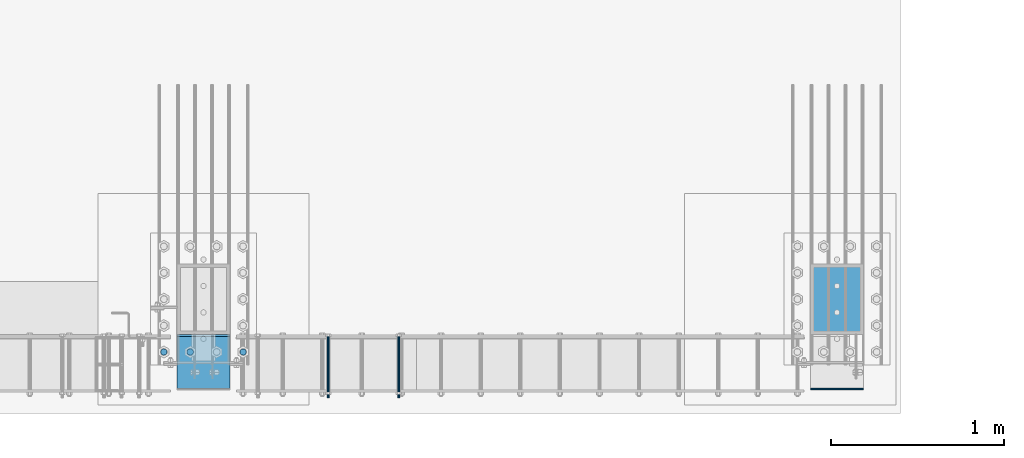
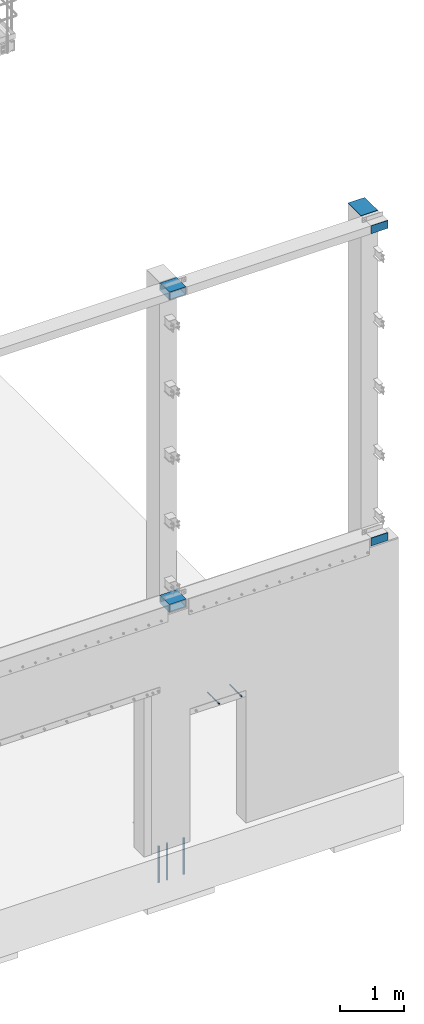
# One storey, part 1087 of 1876: 10 beams, 5 elements without a shape of their own.
"""IFC2X3 building model written with IfcOpenShell, lengths in millimetres."""

from ifc_helpers import new_model, si_unit, frame, origin_with_axes, place, context, subcontext, project, spatial, faceted_brep, material, type_object, element, aggregate, save


model = new_model("IFC2X3")

# Units and contexts
model_context = context("Model", 3, precision=1e-05, world=origin_with_axes())
body_context = subcontext(model_context, "Body", "Model", "MODEL_VIEW")
ifc_project = project(units=[si_unit("LENGTHUNIT", "METRE", prefix="MILLI"), si_unit("AREAUNIT", "SQUARE_METRE"), si_unit("VOLUMEUNIT", "CUBIC_METRE"), si_unit("MASSUNIT", "GRAM", prefix="KILO"), si_unit("TIMEUNIT", "SECOND"), si_unit("PLANEANGLEUNIT", "RADIAN"), si_unit("SOLIDANGLEUNIT", "STERADIAN"), si_unit("THERMODYNAMICTEMPERATUREUNIT", "DEGREE_CELSIUS"), si_unit("LUMINOUSINTENSITYUNIT", "LUMEN")], contexts=[model_context])

# Site, building, storey
site_placement = place(None, origin_with_axes())
site = spatial("IfcSite", under=ifc_project, at=site_placement, CompositionType="ELEMENT")
building_placement = place(site_placement, origin_with_axes())
building = spatial("IfcBuilding", under=site, at=building_placement, Name="Undefined", CompositionType="ELEMENT")
storey_placement = place(building_placement, origin_with_axes())
storey = spatial("IfcBuildingStorey", under=building, at=storey_placement, Name="Undefined", CompositionType="ELEMENT", Elevation=0.0)

# Assembly, beams
assembly_1_placement = place(storey_placement, origin_with_axes())
assembly_1 = element("IfcElementAssembly", 1, at=assembly_1_placement, inside=storey, Name="COLUMN", AssemblyPlace="NOTDEFINED", PredefinedType="RIGID_FRAME")
ifc_material_1 = material()
beam_type_1 = type_object("IfcBeamType", Name="HSS12X6X1/2", PredefinedType="NOTDEFINED")
beam_1_placement = place(assembly_1_placement, frame((3889.375, -25933.4, 10591.8), z_axis=(-1.0, 0.0, 0.0), x_axis=(0.0, 1.0, 0.0)))
beam_1 = element("IfcBeam", 2, at=beam_1_placement, type_object=beam_type_1, material=ifc_material_1, Name="BEAM", ObjectType="HSS12X6X1/2", context=body_context, shape_type="Brep", body=[
    faceted_brep([(330.199999999997, 63.4999999999982, 152.4), (330.200000000004, 63.5, 139.7), (330.200000000004, 63.5, -139.7), (330.200000000004, 63.4999999999982, -152.4), (318.105151367185, 76.2000000000007, -152.4), (318.105151367185, 76.2000000000007, 152.4), (19.0499999999993, -76.2000000000007, 152.4), (19.0499999999993, -76.2000000000007, -152.4), (318.105151367185, -76.2000000000007, -152.4), (318.105151367185, -76.2000000000007, 152.4), (19.0499999999993, 76.2000000000007, 152.4), (19.0499999999993, 76.2000000000007, -152.4), (19.0499999999993, 63.5, 139.7), (19.0499999999993, -63.5, 139.7), (19.0499999999993, -63.5, -139.7), (19.0499999999993, 63.5, -139.7), (330.200000000004, -63.5, 139.7), (330.200000000004, -63.5, -139.7), (330.199999999997, -63.4999999999982, 152.4), (330.200000000004, -63.4999999999982, -152.4)], [[[0, 1, 2, 3, 4, 5]], [[6, 7, 8, 9]], [[7, 6, 10, 11], [12, 13, 14, 15]], [[14, 13, 16, 17]], [[18, 9, 8, 19, 17, 16]], [[10, 6, 9, 18, 0, 5]], [[11, 10, 5, 4]], [[19, 8, 7, 11, 4, 3]], [[17, 19, 3, 2]], [[15, 14, 17, 2]], [[12, 15, 2, 1]], [[13, 12, 1, 16]], [[18, 16, 1, 0]]]),
])
beam_2_placement = place(assembly_1_placement, frame((3889.375, -25923.875, 4597.4), z_axis=(-1.0, 0.0, 0.0), x_axis=(0.0, 1.0, 0.0)))
beam_2 = element("IfcBeam", 3, at=beam_2_placement, type_object=beam_type_1, material=ifc_material_1, Name="BEAM", ObjectType="HSS12X6X1/2", context=body_context, shape_type="Brep", body=[
    faceted_brep([(320.675000000004, 63.5000000000073, 152.400000000001), (320.675000000004, 63.5, 139.700000000001), (320.675000000004, 63.5, -139.700000000001), (320.675000000004, 63.5000000000073, -152.400000000001), (308.580151367183, 76.1999999999998, -152.4), (308.580151367183, 76.1999999999998, 152.4), (9.52499999999452, -76.1999999999998, 152.400000000001), (9.52499999999452, -76.1999999999998, -152.400000000001), (308.580151367183, -76.1999999999998, -152.4), (308.580151367183, -76.1999999999998, 152.4), (9.52499999999452, 76.1999999999998, 152.400000000001), (9.52499999999452, 76.1999999999998, -152.400000000001), (9.52499999999452, 63.5, 139.700000000001), (9.52499999999452, -63.5, 139.700000000001), (9.52499999999452, -63.5, -139.700000000001), (9.52499999999452, 63.5, -139.700000000001), (320.675000000004, -63.5, 139.700000000001), (320.675000000004, -63.5, -139.700000000001), (320.675000000004, -63.5000000000018, 152.400000000001), (320.675000000004, -63.5000000000018, -152.400000000001)], [[[0, 1, 2, 3, 4, 5]], [[6, 7, 8, 9]], [[7, 6, 10, 11], [12, 13, 14, 15]], [[14, 13, 16, 17]], [[18, 9, 8, 19, 17, 16]], [[10, 6, 9, 18, 0, 5]], [[11, 10, 5, 4]], [[19, 8, 7, 11, 4, 3]], [[3, 2, 17, 19]], [[15, 14, 17, 2]], [[12, 15, 2, 1]], [[13, 12, 1, 16]], [[1, 0, 18, 16]]]),
])
aggregate(assembly_1, [beam_1, beam_2])

assembly_2_placement = place(storey_placement, origin_with_axes())
assembly_2 = element("IfcElementAssembly", 4, at=assembly_2_placement, inside=storey, Name="COLUMN", AssemblyPlace="NOTDEFINED", PredefinedType="RIGID_FRAME")
ifc_material_2 = material(Name="STEEL/A36")
beam_type_2 = type_object("IfcBeamType", PredefinedType="NOTDEFINED")
beam_3_placement = place(assembly_2_placement, frame((7699.375, -25919.1125, 4597.4), z_axis=(0.0, 0.0, 1.0), x_axis=(-1.0, 0.0, 0.0)))
beam_3 = element("IfcBeam", 5, at=beam_3_placement, type_object=beam_type_2, material=ifc_material_2, Name="PLATE", context=body_context, shape_type="Brep", body=[
    faceted_brep([(0.0, 4.76249999999982, -76.1999999999998), (3.63797880709171e-12, 4.76249999999982, 76.1999969482422), (304.799999999999, 4.76250000000073, 76.1999999999998), (304.799999999999, 4.76250000000073, -76.1999999999998), (3.63797880709171e-12, -4.76249999999982, 76.1999969482422), (304.799999999999, -4.76250000000073, 76.1999999999998), (0.0, -4.76249999999982, -76.1999999999998), (304.799999999999, -4.76250000000073, -76.1999999999998)], [[[0, 1, 2, 3]], [[1, 4, 5, 2]], [[4, 6, 7, 5]], [[6, 0, 3, 7]], [[5, 7, 3, 2]], [[6, 4, 1, 0]]]),
])
beam_4_placement = place(assembly_2_placement, frame((7699.375, -25919.1125, 10591.8), z_axis=(0.0, 0.0, 1.0), x_axis=(-1.0, 0.0, 0.0)))
beam_4 = element("IfcBeam", 6, at=beam_4_placement, type_object=beam_type_2, material=ifc_material_2, Name="PLATE", context=body_context, shape_type="Brep", body=[
    faceted_brep([(0.0, 4.76249999999982, -76.1999999999998), (3.63797880709171e-12, 4.76249999999982, 76.1999969482422), (304.799999999999, 4.76250000000073, 76.1999999999998), (304.799999999999, 4.76250000000073, -76.1999999999998), (3.63797880709171e-12, -4.76249999999982, 76.1999969482422), (304.799999999999, -4.76250000000073, 76.1999999999998), (0.0, -4.76249999999982, -76.1999999999998), (304.799999999999, -4.76250000000073, -76.1999999999998)], [[[0, 1, 2, 3]], [[1, 4, 5, 2]], [[4, 6, 7, 5]], [[6, 0, 3, 7]], [[5, 7, 3, 2]], [[6, 4, 1, 0]]]),
])

# Assembly, beam
assembly_3_placement = place(storey_placement, origin_with_axes())
assembly_3 = element("IfcElementAssembly", 7, at=assembly_3_placement, inside=storey, Name="ANCHOR_BOLT", AssemblyPlace="NOTDEFINED", PredefinedType="RIGID_FRAME")
beam_type_3 = type_object("IfcBeamType", PredefinedType="NOTDEFINED")
beam_5_placement = place(assembly_3_placement, frame((4610.10979190826, -25969.9124969811, 2493.96240386963), z_axis=(0.0, 0.0, 1.0), x_axis=(-2.91149999876944e-05, 0.999999999576158, 0.0)))
beam_5 = element("IfcBeam", 8, at=beam_5_placement, type_object=beam_type_3, material=ifc_material_2, Name="ANCHOR_BOLT", context=body_context, shape_type="Brep", body=[
    faceted_brep([(0.0, -7.9375, 0.0), (0.0, -5.61266007566822, -5.61266007566883), (369.887490732475, -5.61266007567792, -5.61266007566837), (369.887490732477, -7.93750000000978, 0.0), (0.0, 0.0, -7.9375), (369.88749073247, -9.54969436861575e-12, -7.9375), (0.0, 5.61266007566822, -5.61266007566883), (369.887490732464, 5.6126600756586, -5.61266007566837), (0.0, 7.9375, 0.0), (369.887490732463, 7.93749999999045, 0.0), (0.0, 5.61266007566822, 5.61266007566883), (369.887490732464, 5.6126600756586, 5.61266007566837), (0.0, 0.0, 7.9375), (369.88749073247, -9.54969436861575e-12, 7.9375), (0.0, -5.61266007566822, 5.61266007566883), (369.887490732475, -5.61266007567792, 5.61266007566837)], [[[0, 1, 2, 3]], [[1, 4, 5, 2]], [[4, 6, 7, 5]], [[6, 8, 9, 7]], [[8, 10, 11, 9]], [[10, 12, 13, 11]], [[12, 14, 15, 13]], [[14, 0, 3, 15]], [[5, 7, 9, 11, 13, 15, 3, 2]], [[14, 12, 10, 8, 6, 4, 1, 0]]]),
])
aggregate(assembly_3, [beam_5])

assembly_4_placement = place(storey_placement, origin_with_axes())
assembly_4 = element("IfcElementAssembly", 9, at=assembly_4_placement, inside=storey, Name="ANCHOR_BOLT", AssemblyPlace="NOTDEFINED", PredefinedType="RIGID_FRAME")
beam_6_placement = place(assembly_4_placement, frame((5016.50979190826, -25969.9124969811, 2493.96240386963), z_axis=(0.0, 0.0, 1.0), x_axis=(-2.91149999876944e-05, 0.999999999576158, 0.0)))
beam_6 = element("IfcBeam", 10, at=beam_6_placement, type_object=beam_type_3, material=ifc_material_2, Name="ANCHOR_BOLT", context=body_context, shape_type="Brep", body=[
    faceted_brep([(0.0, -7.9375, 0.0), (0.0, -5.61266007566822, -5.61266007566883), (369.887490732475, -5.61266007567792, -5.61266007566837), (369.887490732477, -7.93750000000978, 0.0), (0.0, 0.0, -7.9375), (369.88749073247, -9.54969436861575e-12, -7.9375), (0.0, 5.61266007566822, -5.61266007566883), (369.887490732464, 5.6126600756586, -5.61266007566837), (0.0, 7.9375, 0.0), (369.887490732463, 7.93749999999045, 0.0), (0.0, 5.61266007566822, 5.61266007566883), (369.887490732464, 5.6126600756586, 5.61266007566837), (0.0, 0.0, 7.9375), (369.88749073247, -9.54969436861575e-12, 7.9375), (0.0, -5.61266007566822, 5.61266007566883), (369.887490732475, -5.61266007567792, 5.61266007566837)], [[[0, 1, 2, 3]], [[1, 4, 5, 2]], [[4, 6, 7, 5]], [[6, 8, 9, 7]], [[8, 10, 11, 9]], [[10, 12, 13, 11]], [[12, 14, 15, 13]], [[14, 0, 3, 15]], [[5, 7, 9, 11, 13, 15, 3, 2]], [[14, 12, 10, 8, 6, 4, 1, 0]]]),
])
aggregate(assembly_4, [beam_6])

# Beam
beam_type_4 = type_object("IfcBeamType", PredefinedType="NOTDEFINED")
beam_7_placement = place(assembly_2_placement, frame((7546.975, -25603.2, 10663.2375), z_axis=(1.0, 0.0, 0.0), x_axis=(0.0, 1.0, 0.0)))
beam_7 = element("IfcBeam", 11, at=beam_7_placement, type_object=beam_type_4, material=ifc_material_2, Name="PLATE", context=body_context, shape_type="Brep", body=[
    faceted_brep([(0.0, 4.76250000000073, -152.4), (0.0, 4.76250000000073, 152.4), (406.400000000001, 4.76250000000073, 152.4), (406.400000000001, 4.76250000000073, -152.4), (0.0, -4.76250000000073, 152.4), (406.400000000001, -4.76250000000073, 152.4), (0.0, -4.76250000000073, -152.4), (406.400000000001, -4.76250000000073, -152.4)], [[[0, 1, 2, 3]], [[1, 4, 5, 2]], [[4, 6, 7, 5]], [[6, 0, 3, 7]], [[5, 7, 3, 2]], [[6, 4, 1, 0]]]),
])

aggregate(assembly_2, [beam_7, beam_3, beam_4])

# Assembly, beams
assembly_5_placement = place(storey_placement, origin_with_axes())
assembly_5 = element("IfcElementAssembly", 12, at=assembly_5_placement, inside=storey, Name="PLATE", AssemblyPlace="NOTDEFINED", PredefinedType="RIGID_FRAME")
ifc_material_3 = material(Name="STEEL/F1554-55, S1")
beam_type_5 = type_object("IfcBeamType", PredefinedType="NOTDEFINED")
beam_8_placement = place(assembly_5_placement, frame((3813.17501627604, -25704.8, -63.4999999999993), z_axis=(-1.0, 0.0, 0.0), x_axis=(0.0, 0.0, -1.0)))
beam_8 = element("IfcBeam", 13, at=beam_8_placement, type_object=beam_type_5, material=ifc_material_3, Name="WELDED ANCHORS", context=body_context, shape_type="Brep", body=[
    faceted_brep([(0.0, -19.0500000000002, 0.0), (0.0, -16.4977839420935, -9.52500000000146), (698.499999999999, -16.4977839420935, -9.52499999999964), (698.499999999999, -19.0499999999993, 0.0), (0.0, -9.52500000000009, -16.4977839420935), (698.499999999999, -9.52500000000146, -16.4977839420935), (0.0, 0.0, -19.05), (698.499999999999, 0.0, -19.0500000000002), (0.0, 9.52500000000009, -16.4977839420935), (698.499999999999, 9.52500000000146, -16.4977839420935), (0.0, 16.4977839420935, -9.52500000000146), (698.499999999999, 16.4977839420935, -9.52499999999964), (-9.09494701772928e-13, 19.05, -1.81898940354586e-12), (698.499999999999, 19.0499999999993, 0.0), (0.0, 16.4977839420935, 9.52500000000146), (698.499999999999, 16.4977839420935, 9.52499999999964), (0.0, 9.52500000000009, 16.4977839420935), (698.499999999999, 9.52500000000146, 16.4977839420935), (0.0, 0.0, 19.0499999999993), (698.499999999999, 0.0, 19.0500000000002), (0.0, -9.52500000000009, 16.4977839420935), (698.499999999999, -9.52500000000146, 16.4977839420935), (0.0, -16.4977839420935, 9.52500000000146), (698.499999999999, -16.4977839420935, 9.52499999999964)], [[[0, 1, 2, 3]], [[1, 4, 5, 2]], [[4, 6, 7, 5]], [[6, 8, 9, 7]], [[8, 10, 11, 9]], [[10, 12, 13, 11]], [[12, 14, 15, 13]], [[14, 16, 17, 15]], [[16, 18, 19, 17]], [[18, 20, 21, 19]], [[20, 22, 23, 21]], [[22, 0, 3, 23]], [[5, 7, 9, 11, 13, 15, 17, 19, 21, 23, 3, 2]], [[22, 20, 18, 16, 14, 12, 10, 8, 6, 4, 1, 0]]]),
])
beam_9_placement = place(assembly_5_placement, frame((3660.77502441406, -25704.8, -63.4999999999993), z_axis=(-1.0, 0.0, 0.0), x_axis=(0.0, 0.0, -1.0)))
beam_9 = element("IfcBeam", 14, at=beam_9_placement, type_object=beam_type_5, material=ifc_material_3, Name="WELDED ANCHORS", context=body_context, shape_type="Brep", body=[
    faceted_brep([(0.0, -19.0500000000002, 0.0), (0.0, -16.4977839420935, -9.52500000000146), (698.499999999999, -16.4977839420935, -9.52499999999964), (698.499999999999, -19.0499999999993, 0.0), (0.0, -9.52500000000009, -16.4977839420935), (698.499999999999, -9.52500000000146, -16.4977839420935), (0.0, 0.0, -19.05), (698.499999999999, 0.0, -19.0500000000002), (0.0, 9.52500000000009, -16.4977839420935), (698.499999999999, 9.52500000000146, -16.4977839420935), (0.0, 16.4977839420935, -9.52500000000146), (698.499999999999, 16.4977839420935, -9.52499999999964), (-9.09494701772928e-13, 19.05, -1.81898940354586e-12), (698.499999999999, 19.0499999999993, 0.0), (0.0, 16.4977839420935, 9.52500000000146), (698.499999999999, 16.4977839420935, 9.52499999999964), (0.0, 9.52500000000009, 16.4977839420935), (698.499999999999, 9.52500000000146, 16.4977839420935), (0.0, 0.0, 19.0499999999993), (698.499999999999, 0.0, 19.0500000000002), (0.0, -9.52500000000009, 16.4977839420935), (698.499999999999, -9.52500000000146, 16.4977839420935), (0.0, -16.4977839420935, 9.52500000000146), (698.499999999999, -16.4977839420935, 9.52499999999964)], [[[0, 1, 2, 3]], [[1, 4, 5, 2]], [[4, 6, 7, 5]], [[6, 8, 9, 7]], [[8, 10, 11, 9]], [[10, 12, 13, 11]], [[12, 14, 15, 13]], [[14, 16, 17, 15]], [[16, 18, 19, 17]], [[18, 20, 21, 19]], [[20, 22, 23, 21]], [[22, 0, 3, 23]], [[5, 7, 9, 11, 13, 15, 17, 19, 21, 23, 3, 2]], [[22, 20, 18, 16, 14, 12, 10, 8, 6, 4, 1, 0]]]),
])
beam_10_placement = place(assembly_5_placement, frame((4117.975, -25704.8, -63.4999999999993), z_axis=(-1.0, 0.0, 0.0), x_axis=(0.0, 0.0, -1.0)))
beam_10 = element("IfcBeam", 15, at=beam_10_placement, type_object=beam_type_5, material=ifc_material_3, Name="WELDED ANCHORS", context=body_context, shape_type="Brep", body=[
    faceted_brep([(0.0, -19.0500000000002, 0.0), (0.0, -16.4977839420935, -9.52500000000146), (698.499999999999, -16.4977839420935, -9.52499999999964), (698.499999999999, -19.0499999999993, 0.0), (0.0, -9.52500000000009, -16.4977839420935), (698.499999999999, -9.52500000000146, -16.4977839420935), (0.0, 0.0, -19.05), (698.499999999999, 0.0, -19.0500000000002), (0.0, 9.52500000000009, -16.4977839420935), (698.499999999999, 9.52500000000146, -16.4977839420935), (0.0, 16.4977839420935, -9.52500000000146), (698.499999999999, 16.4977839420935, -9.52499999999964), (-9.09494701772928e-13, 19.05, -1.81898940354586e-12), (698.499999999999, 19.0499999999993, 0.0), (0.0, 16.4977839420935, 9.52500000000146), (698.499999999999, 16.4977839420935, 9.52499999999964), (0.0, 9.52500000000009, 16.4977839420935), (698.499999999999, 9.52500000000146, 16.4977839420935), (0.0, 0.0, 19.0499999999993), (698.499999999999, 0.0, 19.0500000000002), (0.0, -9.52500000000009, 16.4977839420935), (698.499999999999, -9.52500000000146, 16.4977839420935), (0.0, -16.4977839420935, 9.52500000000146), (698.499999999999, -16.4977839420935, 9.52499999999964)], [[[0, 1, 2, 3]], [[1, 4, 5, 2]], [[4, 6, 7, 5]], [[6, 8, 9, 7]], [[8, 10, 11, 9]], [[10, 12, 13, 11]], [[12, 14, 15, 13]], [[14, 16, 17, 15]], [[16, 18, 19, 17]], [[18, 20, 21, 19]], [[20, 22, 23, 21]], [[22, 0, 3, 23]], [[5, 7, 9, 11, 13, 15, 17, 19, 21, 23, 3, 2]], [[22, 20, 18, 16, 14, 12, 10, 8, 6, 4, 1, 0]]]),
])
aggregate(assembly_5, [beam_8, beam_9, beam_10])

save(model, "model.ifc")
